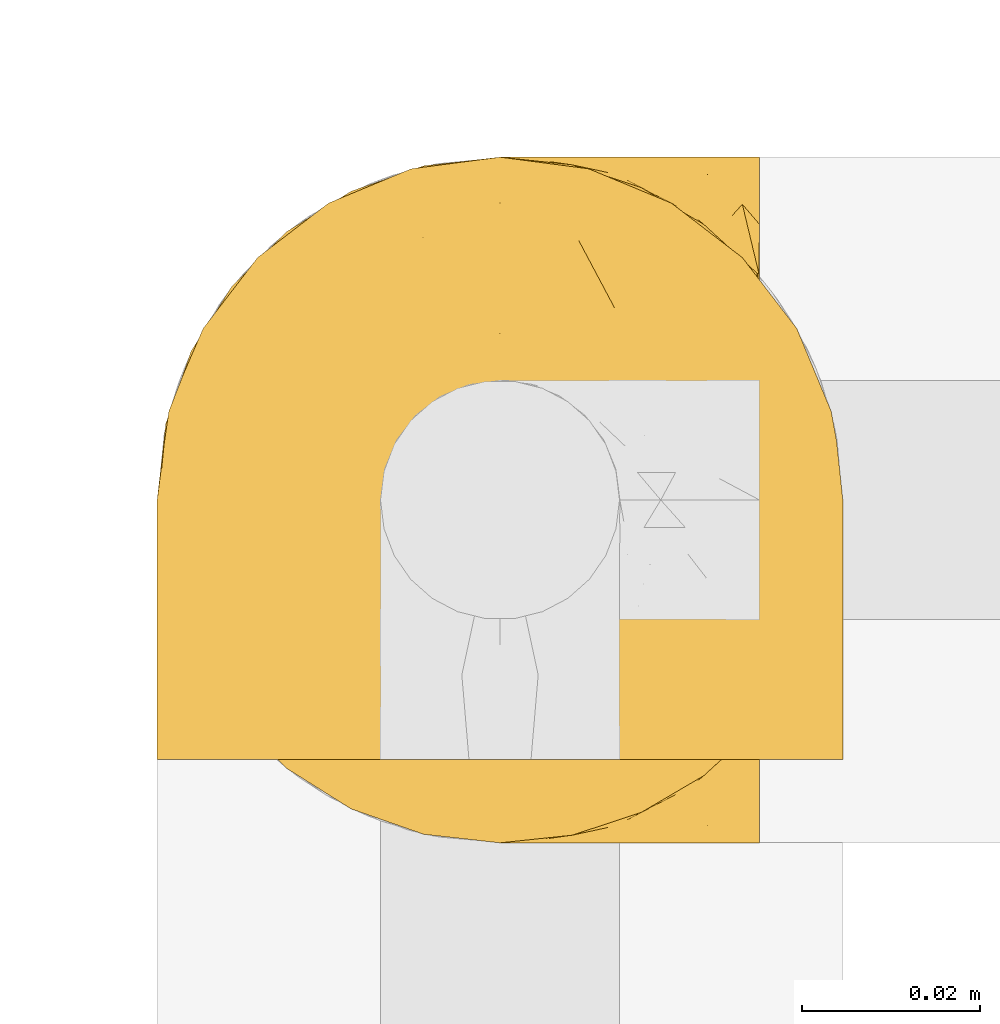
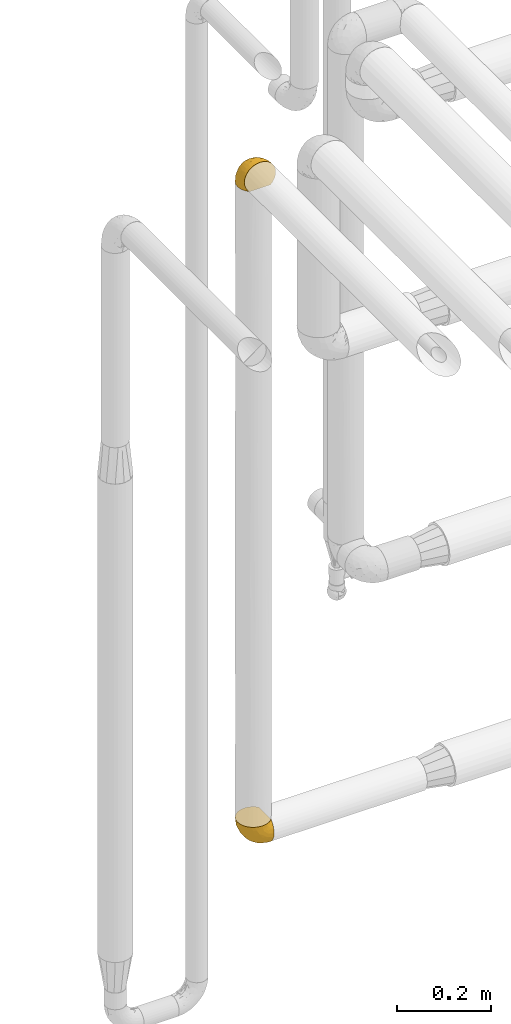
# One storey, part 435 of 827: 2 coverings.
"""IFC2X3 building model written with IfcOpenShell, lengths in millimetres."""

from ifc_helpers import new_model, entity, si_unit, converted_unit, derived_unit, direction, frame, origin, place, context, subcontext, project, spatial, faceted_brep, element, save


model = new_model("IFC2X3")

# Units and contexts
model_context = context("Model", 3, precision=0.01, world=origin(), true_north=direction((6.12303176911189e-17, 1.0)))
body_context = subcontext(model_context, "Body", "Model", "MODEL_VIEW")
ifc_project = project(units=[si_unit("LENGTHUNIT", "METRE", prefix="MILLI"), si_unit("AREAUNIT", "SQUARE_METRE"), si_unit("VOLUMEUNIT", "CUBIC_METRE"), converted_unit("PLANEANGLEUNIT", "DEGREE", entity("IfcRatioMeasure", 0.0174532925199433), si_unit("PLANEANGLEUNIT", "RADIAN"), dimensions=[0, 0, 0, 0, 0, 0, 0]), si_unit("MASSUNIT", "GRAM", prefix="KILO"), derived_unit("MASSDENSITYUNIT", [(si_unit("MASSUNIT", "GRAM", prefix="KILO"), 1), (si_unit("LENGTHUNIT", "METRE"), -3)]), derived_unit("MOMENTOFINERTIAUNIT", [(si_unit("LENGTHUNIT", "METRE"), 4)]), si_unit("TIMEUNIT", "SECOND"), si_unit("FREQUENCYUNIT", "HERTZ"), si_unit("THERMODYNAMICTEMPERATUREUNIT", "DEGREE_CELSIUS"), derived_unit("THERMALTRANSMITTANCEUNIT", [(si_unit("MASSUNIT", "GRAM", prefix="KILO"), 1), (si_unit("THERMODYNAMICTEMPERATUREUNIT", "KELVIN"), -1), (si_unit("TIMEUNIT", "SECOND"), -3)]), derived_unit("VOLUMETRICFLOWRATEUNIT", [(si_unit("LENGTHUNIT", "METRE"), 3), (si_unit("TIMEUNIT", "SECOND"), -1)]), derived_unit("MASSFLOWRATEUNIT", [(si_unit("MASSUNIT", "GRAM", prefix="KILO"), 1), (si_unit("TIMEUNIT", "SECOND"), -1)]), derived_unit("ROTATIONALFREQUENCYUNIT", [(si_unit("TIMEUNIT", "SECOND"), -1)]), si_unit("ELECTRICCURRENTUNIT", "AMPERE"), si_unit("ELECTRICVOLTAGEUNIT", "VOLT"), si_unit("POWERUNIT", "WATT"), si_unit("FORCEUNIT", "NEWTON", prefix="KILO"), si_unit("ILLUMINANCEUNIT", "LUX"), si_unit("LUMINOUSFLUXUNIT", "LUMEN"), si_unit("LUMINOUSINTENSITYUNIT", "CANDELA"), derived_unit("USERDEFINED", [(si_unit("MASSUNIT", "GRAM", prefix="KILO"), -1), (si_unit("LENGTHUNIT", "METRE"), -2), (si_unit("TIMEUNIT", "SECOND"), 3), (si_unit("LUMINOUSFLUXUNIT", "LUMEN"), 1)]), derived_unit("LINEARVELOCITYUNIT", [(si_unit("LENGTHUNIT", "METRE"), 1), (si_unit("TIMEUNIT", "SECOND"), -1)]), si_unit("PRESSUREUNIT", "PASCAL"), derived_unit("USERDEFINED", [(si_unit("LENGTHUNIT", "METRE"), -2), (si_unit("MASSUNIT", "GRAM", prefix="KILO"), 1), (si_unit("TIMEUNIT", "SECOND"), -2)]), derived_unit("LINEARFORCEUNIT", [(si_unit("MASSUNIT", "GRAM", prefix="KILO"), 1), (si_unit("LENGTHUNIT", "METRE"), 1), (si_unit("TIMEUNIT", "SECOND"), -2), (si_unit("LENGTHUNIT", "METRE"), -1)]), derived_unit("PLANARFORCEUNIT", [(si_unit("MASSUNIT", "GRAM", prefix="KILO"), 1), (si_unit("LENGTHUNIT", "METRE"), 1), (si_unit("TIMEUNIT", "SECOND"), -2), (si_unit("LENGTHUNIT", "METRE"), -2)])], contexts=[model_context])

# Site, building, storey
site_placement = place(None, origin())
site = spatial("IfcSite", under=ifc_project, at=site_placement, CompositionType="ELEMENT")
building_placement = place(site_placement, origin())
building = spatial("IfcBuilding", under=site, at=building_placement, CompositionType="ELEMENT")
storey_placement = place(building_placement, frame((0.0, 0.0, 28200.0)))
storey = spatial("IfcBuildingStorey", under=building, at=storey_placement, Name="08", CompositionType="ELEMENT", Elevation=28200.0)

# Coverings
covering_1_placement = place(storey_placement, frame((53869.74, 17459.95, 752.45)))
element("IfcCovering", 1, at=covering_1_placement, inside=storey, Name=":ADSK_", ObjectType=":ADSK_", PredefinedType="INSULATION", context=body_context, shape_type="Brep", body=[
    faceted_brep([(23.36, 74.68, 69.15), (16.07, 70.1, 69.15), (9.98, 64.01, 69.15), (5.4, 56.72, 69.15), (2.56, 48.6, 69.15), (1.6, 40.05, 69.15), (2.56, 31.49, 69.15), (5.41, 23.36, 69.15), (9.99, 16.07, 69.15), (16.08, 9.98, 69.15), (23.37, 5.4, 69.15), (31.49, 2.56, 69.15), (40.05, 1.6, 69.15), (48.15, 2.46, 69.15), (55.88, 5.01, 69.15), (62.9, 9.13, 69.15), (68.89, 14.62, 69.15), (68.89, 16.82, 69.15), (68.89, 18.56, 69.15), (68.89, 20.52, 69.15), (68.89, 22.49, 69.15), (68.89, 24.46, 69.15), (68.89, 26.42, 69.15), (68.89, 28.39, 69.15), (68.89, 30.36, 69.15), (68.89, 32.55, 69.15), (68.89, 34.75, 69.15), (68.89, 36.94, 69.15), (68.89, 39.13, 69.15), (68.89, 41.33, 69.15), (68.89, 43.52, 69.15), (68.89, 45.72, 69.15), (68.89, 47.91, 69.15), (68.89, 50.11, 69.15), (68.89, 52.3, 69.15), (68.89, 54.49, 69.15), (68.89, 56.69, 69.15), (68.89, 58.88, 69.15), (68.89, 61.08, 69.15), (68.89, 63.27, 69.15), (68.89, 65.47, 69.15), (62.89, 70.97, 69.15), (55.86, 75.09, 69.15), (48.13, 77.64, 69.15), (40.05, 78.5, 69.15), (31.49, 77.53, 69.15), (69.15, 14.62, 68.89), (69.15, 9.12, 62.89), (69.15, 5.0, 55.87), (69.15, 2.46, 48.14), (69.15, 1.6, 40.05), (69.15, 2.91, 30.09), (69.15, 6.75, 20.82), (69.15, 12.86, 12.86), (69.15, 20.82, 6.75), (69.15, 30.09, 2.91), (69.15, 40.05, 1.6), (69.15, 50.0, 2.91), (69.15, 59.27, 6.75), (69.15, 67.23, 12.86), (69.15, 73.34, 20.82), (69.15, 77.19, 30.09), (69.15, 78.5, 40.05), (69.15, 77.63, 48.14), (69.15, 75.09, 55.87), (69.15, 70.97, 62.89), (69.15, 65.47, 68.89), (69.15, 63.27, 68.89), (69.15, 62.29, 68.89), (69.15, 60.7, 68.89), (69.15, 59.11, 68.89), (69.15, 57.52, 68.89), (69.15, 55.93, 68.89), (69.15, 54.34, 68.89), (69.15, 52.76, 68.89), (69.15, 51.17, 68.89), (69.15, 49.58, 68.89), (69.15, 47.99, 68.89), (69.15, 46.4, 68.89), (69.15, 44.81, 68.89), (69.15, 43.22, 68.89), (69.15, 41.63, 68.89), (69.15, 40.05, 68.89), (69.15, 38.46, 68.89), (69.15, 36.87, 68.89), (69.15, 35.28, 68.89), (69.15, 33.69, 68.89), (69.15, 32.1, 68.89), (69.15, 30.51, 68.89), (69.15, 28.92, 68.89), (69.15, 27.33, 68.89), (69.15, 25.37, 68.89), (69.15, 23.4, 68.89), (69.15, 21.21, 68.89), (69.15, 19.01, 68.89), (69.15, 16.82, 68.89), (68.96, 42.32, 68.97), (68.97, 44.02, 68.96), (68.97, 47.13, 68.97), (68.97, 48.74, 68.97), (68.95, 23.57, 68.98), (68.96, 25.13, 68.97), (68.98, 61.34, 68.96), (68.97, 22.02, 68.96), (68.97, 29.72, 68.96), (68.98, 56.73, 68.96), (68.97, 55.14, 68.96), (68.97, 37.66, 68.96), (68.94, 64.12, 69.0), (68.98, 28.13, 68.96), (68.98, 26.62, 68.96), (68.96, 31.46, 68.97), (68.97, 16.16, 68.96), (68.98, 39.16, 68.96), (68.98, 50.37, 68.96), (68.97, 17.69, 68.97), (68.96, 19.17, 68.97), (68.97, 62.78, 68.97), (68.97, 58.35, 68.96), (68.98, 45.53, 68.96), (68.96, 59.91, 68.97), (68.97, 65.47, 68.97), (68.94, 65.47, 69.02), (68.92, 65.47, 69.08), (68.97, 14.62, 68.97), (69.02, 14.62, 68.94), (69.08, 14.62, 68.92), (68.98, 20.59, 68.96), (68.97, 32.99, 68.96), (68.98, 34.48, 68.95), (68.97, 51.91, 68.96), (69.08, 65.47, 68.92), (69.02, 65.47, 68.94), (68.96, 53.48, 68.98), (68.92, 14.62, 69.08), (68.94, 14.62, 69.02), (68.97, 40.77, 68.96), (68.96, 35.97, 68.97), (67.02, 7.84, 61.33), (63.33, 3.53, 53.1), (64.61, 8.32, 63.33), (49.27, 1.6, 49.27), (51.4, 2.19, 55.53), (43.94, 1.6, 54.6), (61.87, 1.6, 41.99), (61.54, 4.57, 57.07), (57.95, 3.96, 57.95), (56.12, 2.28, 51.56), (63.4, 1.6, 41.58), (65.41, 7.69, 61.7), (53.1, 3.53, 63.33), (63.04, 8.32, 65.0), (61.33, 7.84, 67.02), (41.99, 1.6, 61.87), (54.6, 1.6, 43.94), (56.6, 4.34, 61.21), (41.58, 1.6, 63.4), (13.72, 29.63, 33.11), (5.82, 27.34, 52.82), (6.74, 40.05, 43.3), (58.82, 2.39, 33.73), (51.58, 2.43, 36.52), (42.09, 9.07, 24.87), (46.12, 16.64, 14.17), (55.56, 9.54, 18.43), (52.38, 4.52, 28.67), (61.54, 4.52, 26.0), (23.76, 7.49, 49.25), (20.5, 7.49, 59.72), (14.64, 12.85, 55.1), (41.77, 2.35, 44.72), (16.28, 22.66, 34.15), (49.4, 32.9, 5.25), (52.34, 25.33, 6.75), (4.3, 40.05, 55.54), (58.67, 16.64, 10.47), (25.26, 19.99, 25.49), (20.17, 16.37, 35.53), (34.7, 3.26, 48.22), (28.67, 3.75, 58.71), (8.62, 19.58, 57.42), (33.37, 7.5, 34.84), (41.35, 4.04, 36.87), (17.15, 13.94, 45.01), (12.68, 19.58, 44.4), (21.47, 28.21, 23.96), (41.11, 24.75, 11.2), (37.53, 31.42, 10.56), (30.64, 26.2, 16.81), (26.66, 33.36, 17.38), (21.38, 40.05, 21.38), (14.06, 40.05, 32.34), (55.54, 40.05, 4.3), (35.17, 16.14, 20.65), (29.04, 12.85, 29.66), (24.34, 10.47, 39.6), (29.33, 6.49, 42.55), (43.3, 40.05, 6.74), (32.34, 40.05, 14.06), (57.75, 75.57, 26.84), (49.41, 47.37, 5.28), (27.85, 52.91, 18.52), (13.7, 50.46, 33.13), (14.63, 67.23, 55.1), (8.61, 60.5, 57.43), (48.85, 70.55, 20.72), (54.13, 63.45, 11.46), (37.84, 62.61, 17.69), (23.75, 72.6, 49.26), (20.49, 72.6, 59.73), (28.66, 76.34, 58.71), (20.83, 59.34, 29.72), (55.15, 77.76, 35.35), (54.6, 78.5, 43.94), (61.87, 78.5, 41.99), (41.58, 78.5, 63.4), (57.58, 53.16, 4.93), (59.91, 70.55, 17.46), (36.94, 48.88, 10.94), (45.72, 54.76, 8.92), (5.82, 52.74, 52.83), (37.91, 71.93, 29.34), (50.18, 75.79, 30.26), (12.67, 60.5, 44.4), (49.29, 77.86, 39.06), (42.64, 77.64, 43.06), (43.94, 78.5, 54.6), (49.27, 78.5, 49.27), (19.45, 67.23, 42.69), (34.7, 76.82, 48.2), (41.99, 78.5, 61.87), (62.29, 77.8, 33.44), (29.01, 67.23, 29.67), (31.47, 73.2, 38.5), (37.18, 67.66, 23.35), (43.45, 75.99, 34.97), (63.33, 76.57, 53.1), (67.23, 73.21, 59.68), (66.07, 71.93, 62.19), (65.22, 71.07, 64.11), (61.99, 75.09, 57.97), (57.95, 76.13, 57.95), (53.09, 76.57, 63.33), (56.84, 77.69, 51.77), (61.33, 72.26, 67.02), (63.06, 71.77, 64.98), (51.41, 77.9, 55.53), (56.61, 75.75, 61.22)], [[[0, 1, 2, 3, 4, 5, 6, 7, 8, 9, 10, 11, 12, 13, 14, 15, 16, 17, 18, 19, 20, 21, 22, 23, 24, 25, 26, 27, 28, 29, 30, 31, 32, 33, 34, 35, 36, 37, 38, 39, 40, 41, 42, 43, 44, 45]], [[46, 47, 48, 49, 50, 51, 52, 53, 54, 55, 56, 57, 58, 59, 60, 61, 62, 63, 64, 65, 66, 67, 68, 69, 70, 71, 72, 73, 74, 75, 76, 77, 78, 79, 80, 81, 82, 83, 84, 85, 86, 87, 88, 89, 90, 91, 92, 93, 94, 95]], [[96, 97, 30]], [[98, 77, 99]], [[100, 101, 21]], [[69, 68, 102]], [[20, 19, 103]], [[24, 23, 104]], [[20, 103, 100]], [[72, 105, 106]], [[84, 83, 107]], [[89, 88, 104]], [[108, 67, 66]], [[109, 110, 90]], [[111, 25, 24]], [[112, 17, 16]], [[82, 113, 83]], [[109, 23, 22]], [[114, 76, 75]], [[105, 36, 106]], [[104, 111, 24]], [[18, 115, 116]], [[97, 96, 80]], [[67, 108, 117]], [[105, 71, 118]], [[31, 97, 119]], [[102, 120, 69]], [[108, 121, 122, 123, 40]], [[112, 95, 115]], [[17, 115, 18]], [[94, 116, 115]], [[117, 68, 67]], [[38, 117, 39]], [[112, 124, 125, 126, 46]], [[17, 112, 115]], [[70, 120, 118]], [[39, 117, 108]], [[120, 38, 37]], [[120, 37, 118]], [[120, 70, 69]], [[116, 94, 127]], [[128, 86, 129]], [[117, 38, 102]], [[74, 130, 75]], [[99, 33, 32]], [[115, 95, 94]], [[39, 108, 40]], [[108, 66, 131, 132, 121]], [[105, 72, 71]], [[118, 37, 36]], [[71, 70, 118]], [[35, 106, 36]], [[36, 105, 118]], [[35, 133, 106]], [[74, 73, 133]], [[106, 133, 73]], [[99, 114, 33]], [[133, 35, 34]], [[73, 72, 106]], [[95, 112, 46]], [[112, 16, 134, 135, 124]], [[130, 114, 75]], [[99, 76, 114]], [[114, 130, 33]], [[34, 33, 130]], [[78, 77, 98]], [[98, 119, 78]], [[130, 133, 34]], [[133, 130, 74]], [[79, 97, 80]], [[98, 99, 32]], [[98, 32, 31]], [[77, 76, 99]], [[97, 79, 119]], [[136, 96, 29]], [[30, 97, 31]], [[136, 29, 28]], [[81, 80, 96]], [[29, 96, 30]], [[31, 119, 98]], [[119, 79, 78]], [[96, 136, 81]], [[82, 81, 136]], [[113, 107, 83]], [[84, 107, 137]], [[107, 27, 137]], [[113, 28, 107]], [[27, 107, 28]], [[85, 84, 137]], [[137, 27, 26]], [[113, 136, 28]], [[136, 113, 82]], [[109, 89, 104]], [[86, 85, 129]], [[89, 109, 90]], [[111, 87, 128]], [[26, 129, 137]], [[88, 111, 104]], [[25, 111, 128]], [[22, 110, 109]], [[23, 109, 104]], [[110, 91, 90]], [[100, 92, 101]], [[110, 22, 101]], [[91, 110, 101]], [[116, 19, 18]], [[111, 88, 87]], [[127, 103, 19]], [[25, 128, 26]], [[86, 128, 87]], [[128, 129, 26]], [[137, 129, 85]], [[120, 102, 38]], [[117, 102, 68]], [[91, 101, 92]], [[21, 101, 22]], [[93, 92, 103]], [[100, 21, 20]], [[100, 103, 92]], [[127, 93, 103]], [[93, 127, 94]], [[116, 127, 19]], [[126, 138, 47]], [[48, 138, 139]], [[140, 125, 124]], [[141, 142, 143]], [[144, 49, 139]], [[145, 140, 146]], [[48, 139, 49]], [[139, 145, 147]], [[49, 144, 148, 50]], [[126, 125, 149]], [[14, 13, 150]], [[151, 146, 140]], [[149, 140, 145]], [[152, 151, 135]], [[152, 14, 150]], [[16, 15, 134]], [[13, 153, 150]], [[124, 151, 140]], [[141, 147, 142]], [[14, 152, 15]], [[15, 152, 134]], [[47, 46, 126]], [[139, 154, 144]], [[138, 48, 47]], [[125, 140, 149]], [[135, 134, 152]], [[146, 155, 142]], [[145, 146, 147]], [[149, 139, 138]], [[147, 141, 154]], [[147, 146, 142]], [[139, 147, 154]], [[139, 149, 145]], [[149, 138, 126]], [[155, 146, 151]], [[150, 143, 142]], [[152, 155, 151]], [[150, 142, 155]], [[13, 12, 156, 153]], [[153, 143, 150]], [[152, 150, 155]], [[151, 124, 135]], [[157, 158, 159]], [[160, 154, 161]], [[162, 163, 164]], [[165, 166, 160]], [[167, 168, 169]], [[141, 170, 161]], [[156, 12, 11]], [[158, 157, 171]], [[172, 55, 173]], [[158, 6, 174]], [[175, 54, 53]], [[52, 166, 164]], [[52, 164, 53]], [[54, 175, 173]], [[166, 52, 51]], [[176, 177, 171]], [[178, 143, 179]], [[156, 11, 179]], [[8, 7, 180]], [[169, 9, 8]], [[179, 143, 153, 156]], [[179, 11, 10]], [[168, 179, 10]], [[181, 162, 182]], [[179, 167, 178]], [[183, 184, 177]], [[183, 169, 184]], [[176, 171, 185]], [[172, 186, 187]], [[158, 7, 6]], [[159, 158, 174]], [[184, 180, 158]], [[54, 173, 55]], [[180, 169, 8]], [[188, 189, 187]], [[9, 168, 10]], [[186, 188, 187]], [[190, 157, 159, 191]], [[55, 172, 192]], [[176, 193, 194]], [[161, 170, 182]], [[162, 164, 165]], [[175, 164, 163]], [[51, 50, 148]], [[167, 195, 196]], [[178, 182, 170]], [[6, 5, 174]], [[158, 180, 7]], [[169, 180, 184]], [[169, 168, 9]], [[179, 168, 167]], [[182, 162, 165]], [[162, 194, 193]], [[161, 165, 160]], [[195, 181, 196]], [[192, 172, 197]], [[192, 56, 55]], [[189, 190, 198]], [[198, 197, 187]], [[172, 187, 197]], [[185, 189, 188]], [[198, 187, 189]], [[186, 172, 173]], [[173, 163, 186]], [[193, 186, 163]], [[176, 185, 188]], [[185, 157, 190]], [[188, 186, 193]], [[177, 176, 194]], [[188, 193, 176]], [[162, 193, 163]], [[195, 177, 194]], [[171, 177, 184]], [[181, 195, 194]], [[183, 167, 169]], [[162, 181, 194]], [[196, 182, 178]], [[158, 171, 184]], [[171, 157, 185]], [[177, 195, 183]], [[167, 183, 195]], [[182, 196, 181]], [[178, 170, 143]], [[178, 167, 196]], [[164, 175, 53]], [[173, 175, 163]], [[160, 51, 148]], [[164, 166, 165]], [[51, 160, 166]], [[160, 148, 144, 154]], [[141, 161, 154]], [[182, 165, 161]], [[190, 189, 185]], [[143, 170, 141]], [[60, 199, 61]], [[197, 200, 192]], [[201, 190, 202]], [[200, 57, 192]], [[203, 204, 2]], [[205, 206, 207]], [[208, 209, 210]], [[211, 207, 201]], [[212, 213, 214]], [[45, 215, 210]], [[216, 206, 58]], [[45, 44, 215]], [[59, 217, 60]], [[60, 217, 199]], [[0, 45, 210]], [[218, 201, 219]], [[202, 159, 220]], [[205, 221, 222]], [[223, 204, 203]], [[1, 203, 2]], [[57, 200, 216]], [[220, 3, 204]], [[220, 174, 4]], [[1, 0, 209]], [[212, 224, 213]], [[225, 226, 227]], [[228, 223, 203]], [[208, 210, 229]], [[210, 226, 229]], [[3, 220, 4]], [[58, 206, 59]], [[209, 203, 1]], [[202, 220, 223]], [[228, 203, 208]], [[202, 211, 201]], [[3, 2, 204]], [[202, 190, 191, 159]], [[210, 215, 230, 226]], [[199, 212, 231]], [[232, 233, 221]], [[233, 208, 229]], [[207, 206, 219]], [[217, 206, 205]], [[227, 224, 225]], [[233, 232, 228]], [[201, 207, 219]], [[234, 232, 221]], [[218, 219, 200]], [[202, 223, 211]], [[174, 220, 159]], [[174, 5, 4]], [[61, 231, 62]], [[220, 204, 223]], [[210, 209, 0]], [[203, 209, 208]], [[225, 233, 229]], [[224, 227, 213]], [[221, 233, 235]], [[57, 56, 192]], [[198, 218, 197]], [[200, 219, 216]], [[201, 198, 190]], [[197, 218, 200]], [[198, 201, 218]], [[206, 216, 219]], [[58, 57, 216]], [[231, 212, 214]], [[222, 212, 199]], [[228, 211, 223]], [[207, 211, 232]], [[62, 231, 214]], [[199, 231, 61]], [[233, 228, 208]], [[211, 228, 232]], [[222, 221, 235]], [[234, 205, 207]], [[206, 217, 59]], [[199, 217, 205]], [[205, 222, 199]], [[224, 222, 235]], [[222, 224, 212]], [[224, 235, 225]], [[233, 225, 235]], [[226, 225, 229]], [[205, 234, 221]], [[207, 232, 234]], [[63, 214, 236]], [[214, 213, 236]], [[214, 63, 62]], [[237, 236, 238]], [[238, 132, 131]], [[236, 237, 64]], [[239, 240, 241]], [[63, 236, 64]], [[131, 66, 65]], [[237, 131, 65]], [[242, 230, 43]], [[237, 65, 64]], [[239, 121, 132]], [[42, 242, 43]], [[241, 240, 243]], [[41, 123, 244]], [[43, 230, 215, 44]], [[244, 122, 245]], [[227, 246, 243]], [[241, 247, 245]], [[121, 239, 245]], [[41, 40, 123]], [[132, 238, 239]], [[244, 42, 41]], [[131, 237, 238]], [[240, 239, 238]], [[245, 239, 241]], [[247, 241, 246]], [[247, 244, 245]], [[238, 236, 240]], [[243, 236, 213]], [[236, 243, 240]], [[227, 226, 246]], [[243, 213, 227]], [[242, 246, 226]], [[243, 246, 241]], [[246, 242, 247]], [[244, 247, 242]], [[242, 226, 230]], [[42, 244, 242]], [[122, 244, 123]], [[122, 121, 245]]]),
])
covering_2_placement = place(storey_placement, frame((53869.74, 17469.3, 2467.47)))
element("IfcCovering", 2, at=covering_2_placement, inside=storey, Name=":ADSK_", ObjectType=":ADSK_", PredefinedType="INSULATION", context=body_context, shape_type="Brep", body=[
    faceted_brep([(74.68, 1.6, 47.38), (70.1, 1.6, 54.67), (64.01, 1.6, 60.76), (56.72, 1.6, 65.34), (48.6, 1.6, 68.18), (40.05, 1.6, 69.15), (31.49, 1.6, 68.18), (23.36, 1.6, 65.33), (16.07, 1.6, 60.75), (9.98, 1.6, 54.66), (5.4, 1.6, 47.37), (2.56, 1.6, 39.25), (1.6, 1.6, 30.7), (2.46, 1.6, 22.59), (5.01, 1.6, 14.86), (9.13, 1.6, 7.84), (14.62, 1.6, 1.85), (16.82, 1.6, 1.85), (18.56, 1.6, 1.85), (20.52, 1.6, 1.85), (22.49, 1.6, 1.85), (24.46, 1.6, 1.85), (26.42, 1.6, 1.85), (28.39, 1.6, 1.85), (30.36, 1.6, 1.85), (32.55, 1.6, 1.85), (34.75, 1.6, 1.85), (36.94, 1.6, 1.85), (39.13, 1.6, 1.85), (41.33, 1.6, 1.85), (43.52, 1.6, 1.85), (45.72, 1.6, 1.85), (47.91, 1.6, 1.85), (50.11, 1.6, 1.85), (52.3, 1.6, 1.85), (54.49, 1.6, 1.85), (56.69, 1.6, 1.85), (58.88, 1.6, 1.85), (61.08, 1.6, 1.85), (63.27, 1.6, 1.85), (65.47, 1.6, 1.85), (70.97, 1.6, 7.85), (75.09, 1.6, 14.88), (77.64, 1.6, 22.61), (78.5, 1.6, 30.7), (77.53, 1.6, 39.26), (14.62, 1.85, 1.6), (9.12, 7.85, 1.6), (5.0, 14.87, 1.6), (2.46, 22.6, 1.6), (1.6, 30.7, 1.6), (2.91, 40.65, 1.6), (6.75, 49.92, 1.6), (12.86, 57.88, 1.6), (20.82, 63.99, 1.6), (30.09, 67.84, 1.6), (40.05, 69.15, 1.6), (50.0, 67.84, 1.6), (59.27, 63.99, 1.6), (67.23, 57.88, 1.6), (73.34, 49.92, 1.6), (77.19, 40.65, 1.6), (78.5, 30.7, 1.6), (77.63, 22.6, 1.6), (75.09, 14.87, 1.6), (70.97, 7.85, 1.6), (65.47, 1.85, 1.6), (63.27, 1.85, 1.6), (62.29, 1.85, 1.6), (60.7, 1.85, 1.6), (59.11, 1.85, 1.6), (57.52, 1.85, 1.6), (55.93, 1.85, 1.6), (54.34, 1.85, 1.6), (52.76, 1.85, 1.6), (51.17, 1.85, 1.6), (49.58, 1.85, 1.6), (47.99, 1.85, 1.6), (46.4, 1.85, 1.6), (44.81, 1.85, 1.6), (43.22, 1.85, 1.6), (41.63, 1.85, 1.6), (40.05, 1.85, 1.6), (38.46, 1.85, 1.6), (36.87, 1.85, 1.6), (35.28, 1.85, 1.6), (33.69, 1.85, 1.6), (32.1, 1.85, 1.6), (30.51, 1.85, 1.6), (28.92, 1.85, 1.6), (27.33, 1.85, 1.6), (25.37, 1.85, 1.6), (23.4, 1.85, 1.6), (21.21, 1.85, 1.6), (19.01, 1.85, 1.6), (16.82, 1.85, 1.6), (42.32, 1.77, 1.78), (44.02, 1.78, 1.77), (47.13, 1.77, 1.78), (48.74, 1.77, 1.77), (23.57, 1.76, 1.79), (25.13, 1.77, 1.78), (61.34, 1.79, 1.76), (22.02, 1.78, 1.77), (29.72, 1.78, 1.77), (56.73, 1.78, 1.76), (55.14, 1.78, 1.77), (37.66, 1.78, 1.77), (64.12, 1.74, 1.8), (28.13, 1.78, 1.76), (26.62, 1.78, 1.77), (31.46, 1.77, 1.78), (16.16, 1.78, 1.77), (39.16, 1.78, 1.77), (50.37, 1.78, 1.76), (17.69, 1.77, 1.77), (19.17, 1.77, 1.78), (62.78, 1.77, 1.77), (58.35, 1.78, 1.77), (45.53, 1.78, 1.77), (59.91, 1.77, 1.78), (65.47, 1.77, 1.77), (65.47, 1.72, 1.8), (65.47, 1.66, 1.82), (14.62, 1.77, 1.77), (14.62, 1.8, 1.72), (14.62, 1.82, 1.66), (20.59, 1.79, 1.76), (32.99, 1.78, 1.77), (34.48, 1.79, 1.76), (51.91, 1.78, 1.77), (65.47, 1.82, 1.66), (65.47, 1.8, 1.72), (53.48, 1.76, 1.78), (14.62, 1.66, 1.82), (14.62, 1.72, 1.8), (40.77, 1.78, 1.77), (35.97, 1.77, 1.78), (7.84, 9.41, 3.72), (3.53, 17.65, 7.41), (8.32, 7.41, 6.13), (1.6, 21.47, 21.47), (2.19, 15.21, 19.34), (1.6, 16.15, 26.8), (1.6, 28.75, 8.87), (4.57, 13.67, 9.2), (3.96, 12.79, 12.79), (2.28, 19.18, 14.62), (1.6, 29.16, 7.34), (7.69, 9.04, 5.33), (3.53, 7.41, 17.64), (8.32, 5.74, 7.7), (7.84, 3.72, 9.41), (1.6, 8.87, 28.75), (1.6, 26.8, 16.15), (4.34, 9.53, 14.14), (1.6, 7.34, 29.16), (29.63, 37.63, 57.02), (27.34, 17.92, 64.92), (40.05, 27.45, 64.0), (2.39, 37.01, 11.92), (2.43, 34.22, 19.16), (9.07, 45.87, 28.65), (16.64, 56.57, 24.62), (9.54, 52.31, 15.19), (4.52, 42.07, 18.36), (4.52, 44.74, 9.2), (7.49, 21.49, 46.98), (7.49, 11.02, 50.24), (12.85, 15.64, 56.1), (2.35, 26.02, 28.97), (22.66, 36.59, 54.46), (32.9, 65.49, 21.34), (25.33, 63.99, 18.4), (40.05, 15.2, 66.44), (16.64, 60.27, 12.07), (19.99, 45.25, 45.49), (16.37, 35.21, 50.57), (3.26, 22.52, 36.04), (3.75, 12.03, 42.07), (19.58, 13.32, 62.12), (7.5, 35.9, 37.37), (4.04, 33.87, 29.39), (13.94, 25.73, 53.59), (19.58, 26.34, 58.06), (28.21, 46.78, 49.27), (24.75, 59.54, 29.63), (31.42, 60.18, 33.21), (26.2, 53.93, 40.1), (33.36, 53.36, 44.08), (40.05, 49.36, 49.36), (40.05, 38.4, 56.68), (40.05, 66.44, 15.2), (16.14, 50.09, 35.57), (12.85, 41.08, 41.7), (10.47, 31.14, 46.4), (6.49, 28.19, 41.41), (40.05, 64.0, 27.45), (40.05, 56.68, 38.4), (75.57, 43.9, 12.99), (47.37, 65.46, 21.33), (52.91, 52.22, 42.89), (50.46, 37.61, 57.04), (67.23, 15.64, 56.11), (60.5, 13.31, 62.13), (70.55, 50.02, 21.89), (63.45, 59.28, 16.62), (62.61, 53.05, 32.9), (72.6, 21.48, 46.99), (72.6, 11.01, 50.25), (76.34, 12.03, 42.08), (59.34, 41.02, 49.91), (77.76, 35.39, 15.6), (78.5, 26.8, 16.15), (78.5, 28.75, 8.87), (78.5, 7.34, 29.16), (53.16, 65.81, 13.16), (70.55, 53.28, 10.83), (48.88, 59.8, 33.8), (54.76, 61.82, 25.02), (52.74, 17.91, 64.92), (71.93, 41.4, 32.83), (75.79, 40.48, 20.56), (60.5, 26.34, 58.07), (77.86, 31.68, 21.46), (77.64, 27.68, 28.1), (78.5, 16.15, 26.8), (78.5, 21.47, 21.47), (67.23, 28.05, 51.29), (76.82, 22.54, 36.04), (78.5, 8.87, 28.75), (77.8, 37.3, 8.45), (67.23, 41.07, 41.73), (73.2, 32.24, 39.27), (67.66, 47.4, 33.56), (75.99, 35.77, 27.29), (76.57, 17.65, 7.41), (73.21, 11.06, 3.51), (71.93, 8.55, 4.68), (71.07, 6.63, 5.52), (75.09, 12.77, 8.75), (76.13, 12.79, 12.79), (76.57, 7.41, 17.65), (77.69, 18.97, 13.9), (72.26, 3.72, 9.42), (71.77, 5.76, 7.68), (77.9, 15.21, 19.33), (75.75, 9.52, 14.13)], [[[0, 1, 2, 3, 4, 5, 6, 7, 8, 9, 10, 11, 12, 13, 14, 15, 16, 17, 18, 19, 20, 21, 22, 23, 24, 25, 26, 27, 28, 29, 30, 31, 32, 33, 34, 35, 36, 37, 38, 39, 40, 41, 42, 43, 44, 45]], [[46, 47, 48, 49, 50, 51, 52, 53, 54, 55, 56, 57, 58, 59, 60, 61, 62, 63, 64, 65, 66, 67, 68, 69, 70, 71, 72, 73, 74, 75, 76, 77, 78, 79, 80, 81, 82, 83, 84, 85, 86, 87, 88, 89, 90, 91, 92, 93, 94, 95]], [[96, 97, 30]], [[98, 77, 99]], [[100, 101, 21]], [[69, 68, 102]], [[20, 19, 103]], [[24, 23, 104]], [[20, 103, 100]], [[72, 105, 106]], [[84, 83, 107]], [[89, 88, 104]], [[108, 67, 66]], [[109, 110, 90]], [[111, 25, 24]], [[112, 17, 16]], [[82, 113, 83]], [[109, 23, 22]], [[114, 76, 75]], [[105, 36, 106]], [[104, 111, 24]], [[18, 115, 116]], [[97, 96, 80]], [[67, 108, 117]], [[105, 71, 118]], [[31, 97, 119]], [[102, 120, 69]], [[108, 121, 122, 123, 40]], [[112, 95, 115]], [[17, 115, 18]], [[94, 116, 115]], [[117, 68, 67]], [[38, 117, 39]], [[112, 124, 125, 126, 46]], [[17, 112, 115]], [[70, 120, 118]], [[39, 117, 108]], [[120, 38, 37]], [[120, 37, 118]], [[120, 70, 69]], [[116, 94, 127]], [[128, 86, 129]], [[117, 38, 102]], [[74, 130, 75]], [[99, 33, 32]], [[115, 95, 94]], [[39, 108, 40]], [[108, 66, 131, 132, 121]], [[105, 72, 71]], [[118, 37, 36]], [[71, 70, 118]], [[35, 106, 36]], [[36, 105, 118]], [[35, 133, 106]], [[74, 73, 133]], [[106, 133, 73]], [[99, 114, 33]], [[133, 35, 34]], [[73, 72, 106]], [[95, 112, 46]], [[112, 16, 134, 135, 124]], [[130, 114, 75]], [[99, 76, 114]], [[114, 130, 33]], [[34, 33, 130]], [[78, 77, 98]], [[98, 119, 78]], [[130, 133, 34]], [[133, 130, 74]], [[79, 97, 80]], [[98, 99, 32]], [[98, 32, 31]], [[77, 76, 99]], [[97, 79, 119]], [[136, 96, 29]], [[30, 97, 31]], [[136, 29, 28]], [[81, 80, 96]], [[29, 96, 30]], [[31, 119, 98]], [[119, 79, 78]], [[96, 136, 81]], [[82, 81, 136]], [[113, 107, 83]], [[84, 107, 137]], [[107, 27, 137]], [[113, 28, 107]], [[27, 107, 28]], [[85, 84, 137]], [[137, 27, 26]], [[113, 136, 28]], [[136, 113, 82]], [[109, 89, 104]], [[86, 85, 129]], [[89, 109, 90]], [[111, 87, 128]], [[26, 129, 137]], [[88, 111, 104]], [[25, 111, 128]], [[22, 110, 109]], [[23, 109, 104]], [[110, 91, 90]], [[100, 92, 101]], [[110, 22, 101]], [[91, 110, 101]], [[116, 19, 18]], [[111, 88, 87]], [[127, 103, 19]], [[25, 128, 26]], [[86, 128, 87]], [[128, 129, 26]], [[137, 129, 85]], [[120, 102, 38]], [[117, 102, 68]], [[91, 101, 92]], [[21, 101, 22]], [[93, 92, 103]], [[100, 21, 20]], [[100, 103, 92]], [[127, 93, 103]], [[93, 127, 94]], [[116, 127, 19]], [[126, 138, 47]], [[48, 138, 139]], [[140, 125, 124]], [[141, 142, 143]], [[144, 49, 139]], [[145, 140, 146]], [[48, 139, 49]], [[139, 145, 147]], [[49, 144, 148, 50]], [[126, 125, 149]], [[14, 13, 150]], [[151, 146, 140]], [[149, 140, 145]], [[152, 151, 135]], [[152, 14, 150]], [[16, 15, 134]], [[13, 153, 150]], [[124, 151, 140]], [[141, 147, 142]], [[14, 152, 15]], [[15, 152, 134]], [[47, 46, 126]], [[139, 154, 144]], [[138, 48, 47]], [[125, 140, 149]], [[135, 134, 152]], [[146, 155, 142]], [[145, 146, 147]], [[149, 139, 138]], [[147, 141, 154]], [[147, 146, 142]], [[139, 147, 154]], [[139, 149, 145]], [[149, 138, 126]], [[155, 146, 151]], [[150, 143, 142]], [[152, 155, 151]], [[150, 142, 155]], [[13, 12, 156, 153]], [[153, 143, 150]], [[152, 150, 155]], [[151, 124, 135]], [[157, 158, 159]], [[160, 154, 161]], [[162, 163, 164]], [[165, 166, 160]], [[167, 168, 169]], [[141, 170, 161]], [[156, 12, 11]], [[158, 157, 171]], [[172, 55, 173]], [[158, 6, 174]], [[175, 54, 53]], [[52, 166, 164]], [[52, 164, 53]], [[54, 175, 173]], [[166, 52, 51]], [[176, 177, 171]], [[178, 143, 179]], [[156, 11, 179]], [[8, 7, 180]], [[169, 9, 8]], [[179, 143, 153, 156]], [[179, 11, 10]], [[168, 179, 10]], [[181, 162, 182]], [[179, 167, 178]], [[183, 184, 177]], [[183, 169, 184]], [[176, 171, 185]], [[172, 186, 187]], [[158, 7, 6]], [[159, 158, 174]], [[184, 180, 158]], [[54, 173, 55]], [[180, 169, 8]], [[188, 189, 187]], [[9, 168, 10]], [[186, 188, 187]], [[190, 157, 159, 191]], [[55, 172, 192]], [[176, 193, 194]], [[161, 170, 182]], [[162, 164, 165]], [[175, 164, 163]], [[51, 50, 148]], [[167, 195, 196]], [[178, 182, 170]], [[6, 5, 174]], [[158, 180, 7]], [[169, 180, 184]], [[169, 168, 9]], [[179, 168, 167]], [[182, 162, 165]], [[162, 194, 193]], [[161, 165, 160]], [[195, 181, 196]], [[192, 172, 197]], [[192, 56, 55]], [[189, 190, 198]], [[198, 197, 187]], [[172, 187, 197]], [[185, 189, 188]], [[198, 187, 189]], [[186, 172, 173]], [[173, 163, 186]], [[193, 186, 163]], [[176, 185, 188]], [[185, 157, 190]], [[188, 186, 193]], [[177, 176, 194]], [[188, 193, 176]], [[162, 193, 163]], [[195, 177, 194]], [[171, 177, 184]], [[181, 195, 194]], [[183, 167, 169]], [[162, 181, 194]], [[196, 182, 178]], [[158, 171, 184]], [[171, 157, 185]], [[177, 195, 183]], [[167, 183, 195]], [[182, 196, 181]], [[178, 170, 143]], [[178, 167, 196]], [[164, 175, 53]], [[173, 175, 163]], [[160, 51, 148]], [[164, 166, 165]], [[51, 160, 166]], [[160, 148, 144, 154]], [[141, 161, 154]], [[182, 165, 161]], [[190, 189, 185]], [[143, 170, 141]], [[60, 199, 61]], [[197, 200, 192]], [[201, 190, 202]], [[200, 57, 192]], [[203, 204, 2]], [[205, 206, 207]], [[208, 209, 210]], [[211, 207, 201]], [[212, 213, 214]], [[45, 215, 210]], [[216, 206, 58]], [[45, 44, 215]], [[59, 217, 60]], [[60, 217, 199]], [[0, 45, 210]], [[218, 201, 219]], [[202, 159, 220]], [[205, 221, 222]], [[223, 204, 203]], [[1, 203, 2]], [[57, 200, 216]], [[220, 3, 204]], [[220, 174, 4]], [[1, 0, 209]], [[212, 224, 213]], [[225, 226, 227]], [[228, 223, 203]], [[208, 210, 229]], [[210, 226, 229]], [[3, 220, 4]], [[58, 206, 59]], [[209, 203, 1]], [[202, 220, 223]], [[228, 203, 208]], [[202, 211, 201]], [[3, 2, 204]], [[202, 190, 191, 159]], [[210, 215, 230, 226]], [[199, 212, 231]], [[232, 233, 221]], [[233, 208, 229]], [[207, 206, 219]], [[217, 206, 205]], [[227, 224, 225]], [[233, 232, 228]], [[201, 207, 219]], [[234, 232, 221]], [[218, 219, 200]], [[202, 223, 211]], [[174, 220, 159]], [[174, 5, 4]], [[61, 231, 62]], [[220, 204, 223]], [[210, 209, 0]], [[203, 209, 208]], [[225, 233, 229]], [[224, 227, 213]], [[221, 233, 235]], [[57, 56, 192]], [[198, 218, 197]], [[200, 219, 216]], [[201, 198, 190]], [[197, 218, 200]], [[198, 201, 218]], [[206, 216, 219]], [[58, 57, 216]], [[231, 212, 214]], [[222, 212, 199]], [[228, 211, 223]], [[207, 211, 232]], [[62, 231, 214]], [[199, 231, 61]], [[233, 228, 208]], [[211, 228, 232]], [[222, 221, 235]], [[234, 205, 207]], [[206, 217, 59]], [[199, 217, 205]], [[205, 222, 199]], [[224, 222, 235]], [[222, 224, 212]], [[224, 235, 225]], [[233, 225, 235]], [[226, 225, 229]], [[205, 234, 221]], [[207, 232, 234]], [[63, 214, 236]], [[214, 213, 236]], [[214, 63, 62]], [[237, 236, 238]], [[238, 132, 131]], [[236, 237, 64]], [[239, 240, 241]], [[63, 236, 64]], [[131, 66, 65]], [[237, 131, 65]], [[242, 230, 43]], [[237, 65, 64]], [[239, 121, 132]], [[42, 242, 43]], [[241, 240, 243]], [[41, 123, 244]], [[43, 230, 215, 44]], [[244, 122, 245]], [[227, 246, 243]], [[241, 243, 246]], [[121, 239, 245]], [[41, 40, 123]], [[132, 238, 239]], [[244, 42, 41]], [[131, 237, 238]], [[240, 239, 238]], [[245, 239, 241]], [[247, 241, 246]], [[247, 244, 245]], [[238, 236, 240]], [[243, 236, 213]], [[236, 243, 240]], [[226, 246, 227]], [[243, 213, 227]], [[226, 242, 246]], [[241, 247, 245]], [[246, 242, 247]], [[244, 247, 242]], [[242, 226, 230]], [[42, 244, 242]], [[122, 244, 123]], [[122, 121, 245]]]),
])

save(model, "model.ifc")
